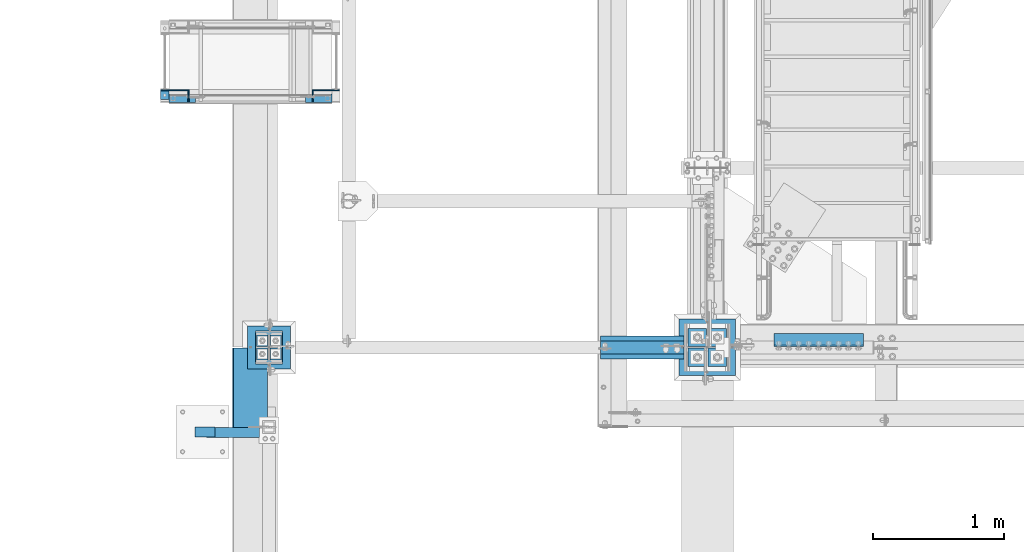
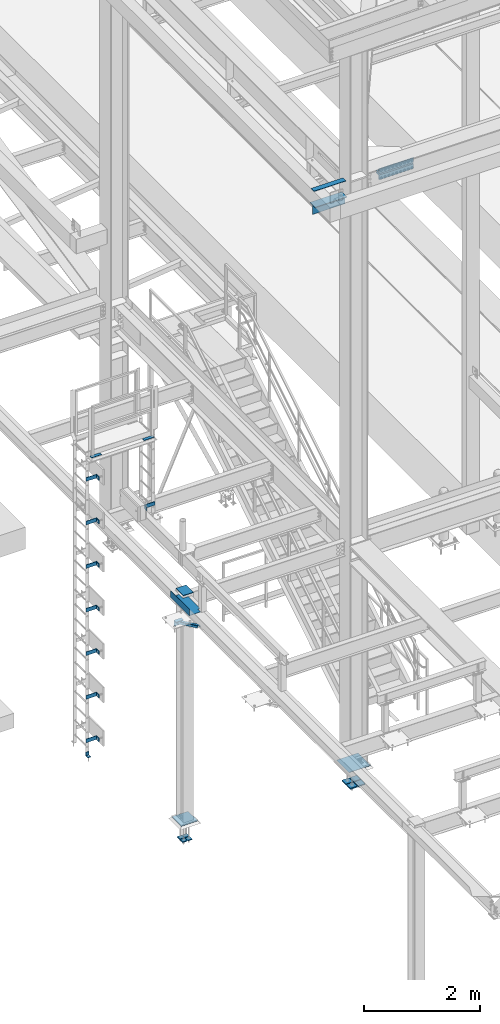
# One storey, part 2013 of 3843: 28 beams, 1 member, 12 elements without a shape of their own.
"""IFC2X3 building model written with IfcOpenShell, lengths in millimetres."""

from ifc_helpers import new_model, si_unit, frame, origin_with_axes, place, context, subcontext, project, spatial, faceted_brep, material, type_object, element, aggregate, save


model = new_model("IFC2X3")

# Units and contexts
model_context = context("Model", 3, precision=1e-05, world=origin_with_axes())
body_context = subcontext(model_context, "Body", "Model", "MODEL_VIEW")
ifc_project = project(units=[si_unit("LENGTHUNIT", "METRE", prefix="MILLI"), si_unit("AREAUNIT", "SQUARE_METRE"), si_unit("VOLUMEUNIT", "CUBIC_METRE"), si_unit("MASSUNIT", "GRAM", prefix="KILO"), si_unit("TIMEUNIT", "SECOND"), si_unit("PLANEANGLEUNIT", "RADIAN"), si_unit("SOLIDANGLEUNIT", "STERADIAN"), si_unit("THERMODYNAMICTEMPERATUREUNIT", "DEGREE_CELSIUS"), si_unit("LUMINOUSINTENSITYUNIT", "LUMEN")], contexts=[model_context])

# Site, building, storey
site_placement = place(None, origin_with_axes())
site = spatial("IfcSite", under=ifc_project, at=site_placement, CompositionType="ELEMENT")
building_placement = place(site_placement, origin_with_axes())
building = spatial("IfcBuilding", under=site, at=building_placement, Name="Undefined", CompositionType="ELEMENT")
storey_placement = place(building_placement, origin_with_axes())
storey = spatial("IfcBuildingStorey", under=building, at=storey_placement, Name="Undefined", CompositionType="ELEMENT", Elevation=0.0)

# Assembly, beams
assembly_1_placement = place(storey_placement, origin_with_axes())
assembly_1 = element("IfcElementAssembly", 1, at=assembly_1_placement, inside=storey, Name="LADDER", AssemblyPlace="NOTDEFINED", PredefinedType="RIGID_FRAME")
ifc_material_1 = material(Name="STEEL/A36")
beam_type_1 = type_object("IfcBeamType", PredefinedType="NOTDEFINED")
beam_1_placement = place(assembly_1_placement, frame((32400.1940668828, 27582.8124999999, 36281.9334228516), z_axis=(0.0, 0.0, 1.0), x_axis=(1.0, 0.0, 0.0)))
beam_1 = element("IfcBeam", 2, at=beam_1_placement, type_object=beam_type_1, material=ifc_material_1, Name="BENT_PLATE", context=body_context, shape_type="Brep", body=[
    faceted_brep([(0.0, -4.76250000000073, -38.0999999999985), (0.0, -4.76250000000073, 38.0999999999985), (0.0, 4.76250000000073, 38.0999999999985), (0.0, 4.76250000000073, -38.0999999999985), (212.923438000009, 4.76249999999345, 38.0999999999985), (212.923438000009, 4.76249999999345, -38.0999999999985), (203.398438000007, -4.762500000008, -38.0999999999985), (203.398438000007, -4.762500000008, 38.0999999999985), (212.923438000009, -87.3125000000073, 38.0999999999985), (212.923438000009, -87.3125000000073, -38.0999999999985), (203.398438000007, -87.3125000000073, 38.0999999999985), (203.398438000007, -87.3125000000073, -38.0999999999985)], [[[0, 1, 2, 3]], [[3, 2, 4, 5]], [[1, 0, 6, 7]], [[5, 4, 8, 9]], [[4, 2, 1, 7, 10, 8]], [[7, 6, 11, 10]], [[6, 0, 3, 5, 9, 11]], [[10, 11, 9, 8]]]),
])
beam_2_placement = place(assembly_1_placement, frame((32400.1940668828, 27582.8124999999, 35367.5334228516), z_axis=(0.0, 0.0, 1.0), x_axis=(1.0, 0.0, 0.0)))
beam_2 = element("IfcBeam", 3, at=beam_2_placement, type_object=beam_type_1, material=ifc_material_1, Name="BENT_PLATE", context=body_context, shape_type="Brep", body=[
    faceted_brep([(0.0, -4.76250000000073, -38.0999999999985), (0.0, -4.76250000000073, 38.0999999999985), (0.0, 4.76250000000073, 38.0999999999985), (0.0, 4.76250000000073, -38.0999999999985), (212.923438000009, 4.76249999999345, 38.0999999999985), (212.923438000009, 4.76249999999345, -38.0999999999985), (203.398438000007, -4.762500000008, -38.0999999999985), (203.398438000007, -4.762500000008, 38.0999999999985), (212.923438000009, -87.3125000000073, 38.0999999999985), (212.923438000009, -87.3125000000073, -38.0999999999985), (203.398438000007, -87.3125000000073, 38.0999999999985), (203.398438000007, -87.3125000000073, -38.0999999999985)], [[[0, 1, 2, 3]], [[3, 2, 4, 5]], [[1, 0, 6, 7]], [[5, 4, 8, 9]], [[4, 2, 1, 7, 10, 8]], [[7, 6, 11, 10]], [[6, 0, 3, 5, 9, 11]], [[10, 11, 9, 8]]]),
])
beam_3_placement = place(assembly_1_placement, frame((32400.1940668828, 27582.8124999999, 34453.1334228516), z_axis=(0.0, 0.0, 1.0), x_axis=(1.0, 0.0, 0.0)))
beam_3 = element("IfcBeam", 4, at=beam_3_placement, type_object=beam_type_1, material=ifc_material_1, Name="BENT_PLATE", context=body_context, shape_type="Brep", body=[
    faceted_brep([(0.0, -4.76250000000073, -38.0999999999985), (0.0, -4.76250000000073, 38.0999999999985), (0.0, 4.76250000000073, 38.0999999999985), (0.0, 4.76250000000073, -38.0999999999985), (212.923438000009, 4.76249999999345, 38.0999999999985), (212.923438000009, 4.76249999999345, -38.0999999999985), (203.398438000007, -4.762500000008, -38.0999999999985), (203.398438000007, -4.762500000008, 38.0999999999985), (212.923438000009, -87.3125000000073, 38.0999999999985), (212.923438000009, -87.3125000000073, -38.0999999999985), (203.398438000007, -87.3125000000073, 38.0999999999985), (203.398438000007, -87.3125000000073, -38.0999999999985)], [[[0, 1, 2, 3]], [[3, 2, 4, 5]], [[1, 0, 6, 7]], [[5, 4, 8, 9]], [[4, 2, 1, 7, 10, 8]], [[7, 6, 11, 10]], [[6, 0, 3, 5, 9, 11]], [[10, 11, 9, 8]]]),
])
beam_4_placement = place(assembly_1_placement, frame((32400.1940668828, 27582.8124999999, 33538.7334228516), z_axis=(0.0, 0.0, 1.0), x_axis=(1.0, 0.0, 0.0)))
beam_4 = element("IfcBeam", 5, at=beam_4_placement, type_object=beam_type_1, material=ifc_material_1, Name="BENT_PLATE", context=body_context, shape_type="Brep", body=[
    faceted_brep([(0.0, -4.76250000000073, -38.0999999999985), (0.0, -4.76250000000073, 38.0999999999985), (0.0, 4.76250000000073, 38.0999999999985), (0.0, 4.76250000000073, -38.0999999999985), (212.923438000009, 4.76249999999345, 38.0999999999985), (212.923438000009, 4.76249999999345, -38.0999999999985), (203.398438000007, -4.762500000008, -38.0999999999985), (203.398438000007, -4.762500000008, 38.0999999999985), (212.923438000009, -87.3125000000073, 38.0999999999985), (212.923438000009, -87.3125000000073, -38.0999999999985), (203.398438000007, -87.3125000000073, 38.0999999999985), (203.398438000007, -87.3125000000073, -38.0999999999985)], [[[0, 1, 2, 3]], [[3, 2, 4, 5]], [[1, 0, 6, 7]], [[5, 4, 8, 9]], [[4, 2, 1, 7, 10, 8]], [[7, 6, 11, 10]], [[6, 0, 3, 5, 9, 11]], [[10, 11, 9, 8]]]),
])
beam_5_placement = place(assembly_1_placement, frame((32400.1940668828, 27582.8124999999, 32624.3334228516), z_axis=(0.0, 0.0, 1.0), x_axis=(1.0, 0.0, 0.0)))
beam_5 = element("IfcBeam", 6, at=beam_5_placement, type_object=beam_type_1, material=ifc_material_1, Name="BENT_PLATE", context=body_context, shape_type="Brep", body=[
    faceted_brep([(0.0, -4.76250000000073, -38.0999999999985), (0.0, -4.76250000000073, 38.0999999999985), (0.0, 4.76250000000073, 38.0999999999985), (0.0, 4.76250000000073, -38.0999999999985), (212.923438000009, 4.76249999999345, 38.0999999999985), (212.923438000009, 4.76249999999345, -38.0999999999985), (203.398438000007, -4.762500000008, -38.0999999999985), (203.398438000007, -4.762500000008, 38.0999999999985), (212.923438000009, -87.3125000000073, 38.0999999999985), (212.923438000009, -87.3125000000073, -38.0999999999985), (203.398438000007, -87.3125000000073, 38.0999999999985), (203.398438000007, -87.3125000000073, -38.0999999999985)], [[[0, 1, 2, 3]], [[3, 2, 4, 5]], [[1, 0, 6, 7]], [[5, 4, 8, 9]], [[4, 2, 1, 7, 10, 8]], [[7, 6, 11, 10]], [[6, 0, 3, 5, 9, 11]], [[10, 11, 9, 8]]]),
])
beam_6_placement = place(assembly_1_placement, frame((32400.1940668828, 27582.8124999999, 31709.9334228516), z_axis=(0.0, 0.0, 1.0), x_axis=(1.0, 0.0, 0.0)))
beam_6 = element("IfcBeam", 7, at=beam_6_placement, type_object=beam_type_1, material=ifc_material_1, Name="BENT_PLATE", context=body_context, shape_type="Brep", body=[
    faceted_brep([(0.0, -4.76250000000073, -38.0999999999985), (0.0, -4.76250000000073, 38.0999999999985), (0.0, 4.76250000000073, 38.0999999999985), (0.0, 4.76250000000073, -38.0999999999985), (212.923438000009, 4.76249999999345, 38.0999999999985), (212.923438000009, 4.76249999999345, -38.0999999999985), (203.398438000007, -4.762500000008, -38.0999999999985), (203.398438000007, -4.762500000008, 38.0999999999985), (212.923438000009, -87.3125000000073, 38.0999999999985), (212.923438000009, -87.3125000000073, -38.0999999999985), (203.398438000007, -87.3125000000073, 38.0999999999985), (203.398438000007, -87.3125000000073, -38.0999999999985)], [[[0, 1, 2, 3]], [[3, 2, 4, 5]], [[1, 0, 6, 7]], [[5, 4, 8, 9]], [[4, 2, 1, 7, 10, 8]], [[7, 6, 11, 10]], [[6, 0, 3, 5, 9, 11]], [[10, 11, 9, 8]]]),
])

# Assembly, beam
assembly_2_placement = place(storey_placement, origin_with_axes())
assembly_2 = element("IfcElementAssembly", 8, at=assembly_2_placement, inside=storey, Name="LADDER", AssemblyPlace="NOTDEFINED", PredefinedType="RIGID_FRAME")
beam_7_placement = place(assembly_2_placement, frame((33761.4528544921, 27582.8124999999, 35306.0009490967), z_axis=(0.0, 0.0, 1.0), x_axis=(-1.0, 0.0, 0.0)))
beam_7 = element("IfcBeam", 9, at=beam_7_placement, type_object=beam_type_1, material=ifc_material_1, Name="BENT_PLATE", context=body_context, shape_type="Brep", body=[
    faceted_brep([(0.0, -4.76250000000073, -38.0999999999985), (0.0, -4.76250000000073, 38.0999999999985), (0.0, 4.76250000000073, 38.0999999999985), (0.0, 4.76250000000073, -38.0999999999985), (199.032813000005, 4.762500000008, 38.0999999999985), (199.032813000005, 4.762500000008, -38.0999999999985), (208.557812999999, -4.76249999999345, -38.0999999999985), (208.557812999999, -4.76249999999345, 38.0999999999985), (199.032813000005, 87.3125000000109, 38.0999999999985), (199.032813000005, 87.3125000000109, -38.0999999999985), (208.557812999999, 87.3125000000109, 38.0999999999985), (208.557812999999, 87.3125000000109, -38.0999999999985)], [[[0, 1, 2, 3]], [[3, 2, 4, 5]], [[1, 0, 6, 7]], [[5, 4, 8, 9]], [[4, 2, 1, 7, 10, 8]], [[7, 6, 11, 10]], [[6, 0, 3, 5, 9, 11]], [[10, 11, 9, 8]]]),
])
aggregate(assembly_2, [beam_7])

# Beam
beam_8_placement = place(assembly_1_placement, frame((32400.1940668828, 27582.8124999999, 30795.5334228516), z_axis=(0.0, 0.0, 1.0), x_axis=(1.0, 0.0, 0.0)))
beam_8 = element("IfcBeam", 10, at=beam_8_placement, type_object=beam_type_1, material=ifc_material_1, Name="BENT_PLATE", context=body_context, shape_type="Brep", body=[
    faceted_brep([(0.0, -4.76250000000073, -38.0999999999985), (0.0, -4.76250000000073, 38.0999999999985), (0.0, 4.76250000000073, 38.0999999999985), (0.0, 4.76250000000073, -38.0999999999985), (212.923438000009, 4.76249999999345, 38.0999999999985), (212.923438000009, 4.76249999999345, -38.0999999999985), (203.398438000007, -4.762500000008, -38.0999999999985), (203.398438000007, -4.762500000008, 38.0999999999985), (212.923438000009, -87.3125000000073, 38.0999999999985), (212.923438000009, -87.3125000000073, -38.0999999999985), (203.398438000007, -87.3125000000073, 38.0999999999985), (203.398438000007, -87.3125000000073, -38.0999999999985)], [[[0, 1, 2, 3]], [[3, 2, 4, 5]], [[1, 0, 6, 7]], [[5, 4, 8, 9]], [[4, 2, 1, 7, 10, 8]], [[7, 6, 11, 10]], [[6, 0, 3, 5, 9, 11]], [[10, 11, 9, 8]]]),
])

ifc_material_2 = material(Name="STEEL/A572-50")
beam_type_2 = type_object("IfcBeamType", Name="L3X3X3/8", PredefinedType="NOTDEFINED")
beam_9_placement = place(assembly_1_placement, frame((32457.5233459473, 27549.4749999999, 30518.1), z_axis=(0.0, -1.0, 0.0), x_axis=(-1.0, 0.0, 0.0)))
beam_9 = element("IfcBeam", 11, at=beam_9_placement, type_object=beam_type_2, material=ifc_material_2, Name="ANGLE", ObjectType="L3X3X3/8", context=body_context, shape_type="Brep", body=[
    faceted_brep([(0.0, 38.0999999999985, -38.0999999999985), (0.0, 38.0999999999985, 38.0999999999985), (63.5, 38.0999999999985, 38.0999999999985), (63.5, 38.0999999999985, -38.0999999999985), (0.0, 28.5750000000007, 38.0999999999985), (63.5, 28.5750000000007, 38.0999999999985), (0.0, 28.5750000000007, -28.5750000000007), (63.5, 28.5750000000007, -28.5750000000007), (0.0, -38.0999999999985, -28.5750000000007), (63.5, -38.0999999999985, -28.5750000000007), (0.0, -38.0999999999985, -38.0999999999985), (63.5, -38.0999999999985, -38.0999999999985)], [[[0, 1, 2, 3]], [[1, 4, 5, 2]], [[4, 6, 7, 5]], [[6, 8, 9, 7]], [[8, 10, 11, 9]], [[10, 0, 3, 11]], [[5, 7, 9, 11, 3, 2]], [[10, 8, 6, 4, 1, 0]]]),
])

aggregate(assembly_1, [beam_1, beam_2, beam_3, beam_4, beam_5, beam_6, beam_9, beam_8])

# Assembly, beams
assembly_3_placement = place(storey_placement, origin_with_axes())
assembly_3 = element("IfcElementAssembly", 12, at=assembly_3_placement, inside=storey, Name="RAIL", AssemblyPlace="NOTDEFINED", PredefinedType="RIGID_FRAME")
beam_type_3 = type_object("IfcBeamType", PredefinedType="NOTDEFINED")
beam_10_placement = place(assembly_3_placement, frame((33704.6093748092, 27520.8999999999, 36768.7510559082), z_axis=(0.0, -1.0, 0.0), x_axis=(-1.0, 0.0, 0.0)))
beam_10 = element("IfcBeam", 13, at=beam_10_placement, type_object=beam_type_3, material=ifc_material_1, context=body_context, shape_type="Brep", body=[
    faceted_brep([(0.0, 3.17500000000291, -31.75), (0.0, 3.17500000000291, 31.75), (203.199998088516, 3.17500000000291, 31.75), (203.199998088516, 3.17500000000291, -31.75), (0.0, -3.17500000000291, 31.75), (203.199998088516, -3.17500000000291, 31.75), (0.0, -3.17500000000291, -31.75), (203.199998088516, -3.17500000000291, -31.75)], [[[0, 1, 2, 3]], [[1, 4, 5, 2]], [[4, 6, 7, 5]], [[6, 0, 3, 7]], [[5, 7, 3, 2]], [[6, 4, 1, 0]]]),
])
beam_11_placement = place(assembly_3_placement, frame((32660.6296738373, 27520.8999999999, 36768.7510559082), z_axis=(0.0, -1.0, 0.0), x_axis=(-1.0, 0.0, 0.0)))
beam_11 = element("IfcBeam", 14, at=beam_11_placement, type_object=beam_type_3, material=ifc_material_1, context=body_context, shape_type="Brep", body=[
    faceted_brep([(0.0, 3.17500000000291, -31.75), (0.0, 3.17500000000291, 31.75), (203.199998088516, 3.17500000000291, 31.75), (203.199998088516, 3.17500000000291, -31.75), (0.0, -3.17500000000291, 31.75), (203.199998088516, -3.17500000000291, 31.75), (0.0, -3.17500000000291, -31.75), (203.199998088516, -3.17500000000291, -31.75)], [[[0, 1, 2, 3]], [[1, 4, 5, 2]], [[4, 6, 7, 5]], [[6, 0, 3, 7]], [[5, 7, 3, 2]], [[6, 4, 1, 0]]]),
])
aggregate(assembly_3, [beam_10, beam_11])

# Assembly, beam
assembly_4_placement = place(storey_placement, origin_with_axes())
assembly_4 = element("IfcElementAssembly", 15, at=assembly_4_placement, inside=storey, Name="COLUMN", AssemblyPlace="NOTDEFINED", PredefinedType="RIGID_FRAME")
ifc_material_3 = material(Name="STEEL/A992")
beam_type_4 = type_object("IfcBeamType", Name="WT8X18", PredefinedType="NOTDEFINED")
beam_12_placement = place(assembly_4_placement, frame((35760.025, 25615.9, 41962.3875), z_axis=(0.0, 0.0, 1.0), x_axis=(1.0, 0.0, 0.0)))
beam_12 = element("IfcBeam", 16, at=beam_12_placement, type_object=beam_type_4, material=ifc_material_3, Name="BEAM", ObjectType="WT8X18", context=body_context, shape_type="Brep", body=[
    faceted_brep([(-1.45519152283669e-11, 3.96875, -100.012499999997), (-1.45519152283669e-11, 3.96875, 88.9000000000015), (638.175000000003, 3.96875, 88.9000000000015), (638.175000000003, 3.96875, -100.012499999997), (-2.18278728425503e-10, 88.8999999999942, 88.9000000000015), (638.175000000003, 88.9000000000015, 88.9000000000015), (-2.18278728425503e-10, 88.8999999999942, 100.012499999997), (638.175000000003, 88.9000000000015, 100.012499999997), (2.03726813197136e-10, -88.8999999999942, 100.012499999997), (638.175000000003, -88.9000000000015, 100.012499999997), (2.03726813197136e-10, -88.8999999999942, 88.9000000000015), (638.175000000003, -88.9000000000015, 88.9000000000015), (0.0, -3.96875, 88.9000000000015), (638.175000000003, -3.96875, 88.9000000000015), (0.0, -3.96875, -100.012499999997), (638.175000000003, -3.96875, -100.012499999997)], [[[0, 1, 2, 3]], [[1, 4, 5, 2]], [[4, 6, 7, 5]], [[6, 8, 9, 7]], [[8, 10, 11, 9]], [[10, 12, 13, 11]], [[12, 14, 15, 13]], [[14, 0, 3, 15]], [[5, 7, 9, 11, 13, 15, 3, 2]], [[14, 12, 10, 8, 6, 4, 1, 0]]]),
])
aggregate(assembly_4, [beam_12])

assembly_5_placement = place(storey_placement, origin_with_axes())
assembly_5 = element("IfcElementAssembly", 17, at=assembly_5_placement, inside=storey, Name="PLATE", AssemblyPlace="NOTDEFINED", PredefinedType="RIGID_FRAME")
beam_type_5 = type_object("IfcBeamType", PredefinedType="NOTDEFINED")
beam_13_placement = place(assembly_5_placement, frame((35760.025, 25615.9, 42371.9625), z_axis=(0.0, 1.0, 0.0), x_axis=(1.0, 0.0, 0.0)))
beam_13 = element("IfcBeam", 18, at=beam_13_placement, type_object=beam_type_5, material=ifc_material_2, Name="PLATE", context=body_context, shape_type="Brep", body=[
    faceted_brep([(0.0, 4.76249999999709, -50.7999999999993), (0.0, 4.76249999999709, 50.7999999999993), (638.175000000003, 4.76249999999709, 50.7999999999993), (638.175000000003, 4.76249999999709, -50.7999999999993), (0.0, -4.76249999999709, 50.7999999999993), (638.175000000003, -4.76249999999709, 50.7999999999993), (0.0, -4.76249999999709, -50.7999999999993), (638.175000000003, -4.76249999999709, -50.7999999999993)], [[[0, 1, 2, 3]], [[1, 4, 5, 2]], [[4, 6, 7, 5]], [[6, 0, 3, 7]], [[5, 7, 3, 2]], [[6, 4, 1, 0]]]),
])
aggregate(assembly_5, [beam_13])

# Assembly, beams
assembly_6_placement = place(storey_placement, origin_with_axes())
assembly_6 = element("IfcElementAssembly", 19, at=assembly_6_placement, inside=storey, Name="PLATE", AssemblyPlace="NOTDEFINED", PredefinedType="RIGID_FRAME")
beam_type_6 = type_object("IfcBeamType", Name="L4X4X1/2", PredefinedType="NOTDEFINED")
beam_14_placement = place(assembly_6_placement, frame((37084.0000000004, 25673.049999999, 42297.35), z_axis=(0.0, 1.0, 0.0), x_axis=(1.0, 0.0, 0.0)))
beam_14 = element("IfcBeam", 20, at=beam_14_placement, type_object=beam_type_6, material=ifc_material_2, Name="ANGLE", ObjectType="L4X4X1/2", context=body_context, shape_type="Brep", body=[
    faceted_brep([(0.0, 50.8000000000029, -50.8000000000029), (0.0, 50.8000000000029, 50.8000000000029), (685.800000000003, 50.8000000000029, 50.8000000000029), (685.800000000003, 50.8000000000029, -50.8000000000029), (0.0, 38.0999999999985, 50.8000000000029), (685.800000000003, 38.0999999999985, 50.8000000000029), (0.0, 38.0999999999985, -38.0999999999985), (685.800000000003, 38.0999999999985, -38.1000000000058), (0.0, -50.8000000000029, -38.1000000000058), (685.800000000003, -50.8000000000029, -38.1000000000058), (0.0, -50.8000000000029, -50.8000000000029), (685.800000000003, -50.8000000000029, -50.8000000000029)], [[[0, 1, 2, 3]], [[1, 4, 5, 2]], [[4, 6, 7, 5]], [[6, 8, 9, 7]], [[8, 10, 11, 9]], [[10, 0, 3, 11]], [[5, 7, 9, 11, 3, 2]], [[10, 8, 6, 4, 1, 0]]]),
])
beam_15_placement = place(assembly_6_placement, frame((37769.8000000004, 25673.049999994, 42167.175), z_axis=(0.0, 1.0, 0.0), x_axis=(-1.0, 0.0, 0.0)))
beam_15 = element("IfcBeam", 21, at=beam_15_placement, type_object=beam_type_6, material=ifc_material_2, Name="ANGLE", ObjectType="L4X4X1/2", context=body_context, shape_type="Brep", body=[
    faceted_brep([(0.0, 50.8000000000029, -50.8000000000029), (0.0, 50.8000000000029, 50.8000000000029), (685.800000000003, 50.8000000000029, 50.8000000000029), (685.800000000003, 50.8000000000029, -50.8000000000029), (0.0, 38.0999999999985, 50.8000000000029), (685.800000000003, 38.0999999999985, 50.8000000000029), (0.0, 38.0999999999985, -38.0999999999985), (685.800000000003, 38.0999999999985, -38.1000000000058), (0.0, -50.8000000000029, -38.1000000000058), (685.800000000003, -50.8000000000029, -38.1000000000058), (0.0, -50.8000000000029, -50.8000000000029), (685.800000000003, -50.8000000000029, -50.8000000000029)], [[[0, 1, 2, 3]], [[1, 4, 5, 2]], [[4, 6, 7, 5]], [[6, 8, 9, 7]], [[8, 10, 11, 9]], [[10, 0, 3, 11]], [[5, 7, 9, 11, 3, 2]], [[10, 8, 6, 4, 1, 0]]]),
])
aggregate(assembly_6, [beam_14, beam_15])

# Assembly, beam
assembly_7_placement = place(storey_placement, origin_with_axes())
assembly_7 = element("IfcElementAssembly", 22, at=assembly_7_placement, inside=storey, Name="ANGLE", AssemblyPlace="NOTDEFINED", PredefinedType="RIGID_FRAME")
beam_type_7 = type_object("IfcBeamType", Name="L5X3X1/4", PredefinedType="NOTDEFINED")
beam_16_placement = place(assembly_7_placement, frame((32808.7812541416, 24969.7875, 34737.675), z_axis=(0.0, 0.0, -1.0), x_axis=(-1.0, 0.0, 0.0)))
beam_16 = element("IfcBeam", 23, at=beam_16_placement, type_object=beam_type_7, material=ifc_material_2, Name="ANGLE", ObjectType="L5X3X1/4", context=body_context, shape_type="Brep", body=[
    faceted_brep([(0.0, 38.0999999999985, -63.5), (0.0, 38.0999999999985, 63.5), (152.400000000001, 38.0999999999985, 63.5), (152.399999999994, 38.0999999999985, -63.5), (0.0, 31.75, 63.5), (152.400000000001, 31.75, 63.5), (0.0, 31.75, -57.1500000000015), (152.400000000001, 31.75, -57.1500000000015), (0.0, -38.0999999999985, -57.1500000000015), (152.400000000001, -38.0999999999985, -57.1500000000015), (0.0, -38.0999999999985, -63.5), (152.400000000001, -38.0999999999985, -63.5)], [[[0, 1, 2, 3]], [[1, 4, 5, 2]], [[4, 6, 7, 5]], [[6, 8, 9, 7]], [[8, 10, 11, 9]], [[10, 0, 3, 11]], [[5, 7, 9, 11, 3, 2]], [[10, 8, 6, 4, 1, 0]]]),
])
aggregate(assembly_7, [beam_16])

# Assembly, member
assembly_8_placement = place(storey_placement, origin_with_axes())
assembly_8 = element("IfcElementAssembly", 24, at=assembly_8_placement, inside=storey, Name="ANGLE", AssemblyPlace="NOTDEFINED", PredefinedType="RIGID_FRAME")
member_type = type_object("IfcMemberType", Name="L3X3X1/4", PredefinedType="NOTDEFINED")
member_placement = place(assembly_8_placement, frame((32728.2664806695, 24963.4375, 34747.2), z_axis=(0.0, -1.0, 0.0), x_axis=(0.866025404271339, 0.0, -0.499999999156664)))
member = element("IfcMember", 25, at=member_placement, type_object=member_type, material=ifc_material_2, Name="ANGLE", ObjectType="L3X3X1/4", context=body_context, shape_type="Brep", body=[
    faceted_brep([(0.0, 38.0999999999985, -38.0999999999985), (0.0, 38.0999999999985, 38.0999999999985), (467.63681744217, 38.0999999998385, 38.0999999999985), (467.63681744217, 38.0999999998385, -38.0999999999985), (0.0, 31.75, 38.0999999999985), (467.636817442166, 31.7499999998472, 38.0999999999985), (0.0, 31.75, -31.75), (467.636817442166, 31.7499999998472, -31.75), (0.0, -38.0999999999985, -31.75), (467.636817442151, -38.1000000000349, -31.75), (0.0, -38.0999999999985, -38.0999999999985), (467.636817442151, -38.1000000000349, -38.0999999999985)], [[[0, 1, 2, 3]], [[1, 4, 5, 2]], [[4, 6, 7, 5]], [[6, 8, 9, 7]], [[8, 10, 11, 9]], [[10, 0, 3, 11]], [[5, 7, 9, 11, 3, 2]], [[10, 8, 6, 4, 1, 0]]]),
])
aggregate(assembly_8, [member])

# Assembly, beam
assembly_9_placement = place(storey_placement, origin_with_axes())
assembly_9 = element("IfcElementAssembly", 26, at=assembly_9_placement, inside=storey, Name="COLUMN", AssemblyPlace="NOTDEFINED", PredefinedType="RIGID_FRAME")
beam_type_8 = type_object("IfcBeamType", PredefinedType="NOTDEFINED")
beam_17_placement = place(assembly_9_placement, frame((33223.2, 25490.4875, 34855.15), z_axis=(1.0, 0.0, 0.0), x_axis=(0.0, 1.0, 0.0)))
beam_17 = element("IfcBeam", 27, at=beam_17_placement, type_object=beam_type_8, material=ifc_material_2, Name="PLATE", context=body_context, shape_type="Brep", body=[
    faceted_brep([(1.74622982740402e-10, 6.35000000000582, -101.600000000195), (-1.67347025126219e-10, 6.35000000000582, 101.600000000151), (250.825000000001, 6.34999999999854, 101.600000000006), (250.825000000001, 6.34999999999854, -101.600000000006), (-1.67347025126219e-10, -6.35000000000582, 101.600000000151), (250.825000000001, -6.34999999999854, 101.600000000006), (1.74622982740402e-10, -6.35000000000582, -101.600000000195), (250.825000000001, -6.34999999999854, -101.600000000006)], [[[0, 1, 2, 3]], [[1, 4, 5, 2]], [[4, 6, 7, 5]], [[6, 0, 3, 7]], [[5, 7, 3, 2]], [[6, 4, 1, 0]]]),
])
aggregate(assembly_9, [beam_17])

# Assembly, beams
assembly_10_placement = place(storey_placement, origin_with_axes())
assembly_10 = element("IfcElementAssembly", 28, at=assembly_10_placement, inside=storey, Name="TEMPLATE", AssemblyPlace="NOTDEFINED", PredefinedType="RIGID_FRAME")
beam_type_9 = type_object("IfcBeamType", PredefinedType="NOTDEFINED")
beam_18_placement = place(assembly_10_placement, frame((33172.4, 25520.65, 29659.2625), z_axis=(1.0, 0.0, 0.0), x_axis=(0.0, 1.0, 0.0)))
beam_18 = element("IfcBeam", 29, at=beam_18_placement, type_object=beam_type_9, material=ifc_material_2, context=body_context, shape_type="Brep", body=[
    faceted_brep([(0.0, 7.9375, -44.4499999999971), (0.0, 7.9375, 44.4499999999971), (88.8999999999942, 7.9375, 44.4499999999971), (88.8999999999942, 7.9375, -44.4499999999971), (0.0, -7.9375, 44.4499999999971), (88.8999999999942, -7.9375, 44.4499999999971), (0.0, -7.9375, -44.4499999999971), (88.8999999999942, -7.9375, -44.4499999999971)], [[[0, 1, 2, 3]], [[1, 4, 5, 2]], [[4, 6, 7, 5]], [[6, 0, 3, 7]], [[5, 7, 3, 2]], [[6, 4, 1, 0]]]),
])
beam_19_placement = place(assembly_10_placement, frame((33274.0, 25520.65, 29659.2625), z_axis=(1.0, 0.0, 0.0), x_axis=(0.0, 1.0, 0.0)))
beam_19 = element("IfcBeam", 30, at=beam_19_placement, type_object=beam_type_9, material=ifc_material_2, context=body_context, shape_type="Brep", body=[
    faceted_brep([(0.0, 7.9375, -44.4499999999971), (0.0, 7.9375, 44.4499999999971), (88.8999999999942, 7.9375, 44.4499999999971), (88.8999999999942, 7.9375, -44.4499999999971), (0.0, -7.9375, 44.4499999999971), (88.8999999999942, -7.9375, 44.4499999999971), (0.0, -7.9375, -44.4499999999971), (88.8999999999942, -7.9375, -44.4499999999971)], [[[0, 1, 2, 3]], [[1, 4, 5, 2]], [[4, 6, 7, 5]], [[6, 0, 3, 7]], [[5, 7, 3, 2]], [[6, 4, 1, 0]]]),
])
beam_20_placement = place(assembly_10_placement, frame((33172.4, 25622.25, 29659.2625), z_axis=(1.0, 0.0, 0.0), x_axis=(0.0, 1.0, 0.0)))
beam_20 = element("IfcBeam", 31, at=beam_20_placement, type_object=beam_type_9, material=ifc_material_2, context=body_context, shape_type="Brep", body=[
    faceted_brep([(0.0, 7.9375, -44.4499999999971), (0.0, 7.9375, 44.4499999999971), (88.8999999999942, 7.9375, 44.4499999999971), (88.8999999999942, 7.9375, -44.4499999999971), (0.0, -7.9375, 44.4499999999971), (88.8999999999942, -7.9375, 44.4499999999971), (0.0, -7.9375, -44.4499999999971), (88.8999999999942, -7.9375, -44.4499999999971)], [[[0, 1, 2, 3]], [[1, 4, 5, 2]], [[4, 6, 7, 5]], [[6, 0, 3, 7]], [[5, 7, 3, 2]], [[6, 4, 1, 0]]]),
])
beam_21_placement = place(assembly_10_placement, frame((33274.0, 25622.25, 29659.2625), z_axis=(1.0, 0.0, 0.0), x_axis=(0.0, 1.0, 0.0)))
beam_21 = element("IfcBeam", 32, at=beam_21_placement, type_object=beam_type_9, material=ifc_material_2, context=body_context, shape_type="Brep", body=[
    faceted_brep([(0.0, 7.9375, -44.4499999999971), (0.0, 7.9375, 44.4499999999971), (88.8999999999942, 7.9375, 44.4499999999971), (88.8999999999942, 7.9375, -44.4499999999971), (0.0, -7.9375, 44.4499999999971), (88.8999999999942, -7.9375, 44.4499999999971), (0.0, -7.9375, -44.4499999999971), (88.8999999999942, -7.9375, -44.4499999999971)], [[[0, 1, 2, 3]], [[1, 4, 5, 2]], [[4, 6, 7, 5]], [[6, 0, 3, 7]], [[5, 7, 3, 2]], [[6, 4, 1, 0]]]),
])

# Assembly, beam
assembly_11_placement = place(storey_placement, origin_with_axes())
assembly_11 = element("IfcElementAssembly", 33, at=assembly_11_placement, inside=storey, Name="BEAM", AssemblyPlace="NOTDEFINED", PredefinedType="RIGID_FRAME")
beam_type_10 = type_object("IfcBeamType", PredefinedType="NOTDEFINED")
beam_22_placement = place(assembly_11_placement, frame((33210.5, 25292.05, 34813.875), z_axis=(0.0, -1.0, 0.0), x_axis=(-1.0, 0.0, 0.0)))
beam_22 = element("IfcBeam", 34, at=beam_22_placement, type_object=beam_type_10, material=ifc_material_1, Name="BENT_PLATE", context=body_context, shape_type="Brep", body=[
    faceted_brep([(44.4500000000044, -3.17500000000291, 228.599999999999), (44.4500000000044, 3.17500000000291, 228.599999999999), (0.0, 3.17500000000291, 228.599999999999), (0.0, -3.17500000000291, 228.599999999999), (44.4500000000044, 0.0, 320.675500000001), (44.4500000000044, 3.17500000000291, 320.675500000001), (44.4500000000044, -3.17500000000291, 317.500500000013), (0.0, -3.17500000000291, -185.737500000007), (0.0, 3.17500000000291, -185.737500000007), (101.60000000002, 3.17500000000291, -185.737500000014), (101.60000000002, -3.17500000000291, -185.737500000014), (101.599999999991, 3.17500000000291, -320.675500000001), (101.599999999991, -3.17500000000291, -320.675500000001), (266.700012207031, 3.17500000000291, -320.675500000001), (266.700012207031, -136.524996948239, -320.675500000001), (260.350012207025, -136.524996948239, -320.675500000001), (260.350012207025, -3.17500000000291, -320.675500000001), (266.700012207031, 3.17500000000291, 320.675500000001), (266.700012207031, -136.524996948239, 320.675500000001), (263.525012207036, -136.524996948239, 320.675500000016), (260.350012207025, -136.524996948239, 317.500500000013), (260.350012207025, -3.17500000000291, 317.500500000013), (263.525012207036, 7.27595761418343e-12, 320.675500000016)], [[[0, 1, 2, 3]], [[4, 5, 1, 0, 6]], [[7, 8, 9, 10]], [[10, 9, 11, 12]], [[13, 14, 15, 16, 12, 11]], [[13, 17, 18, 14]], [[15, 14, 18, 19, 20]], [[16, 15, 20, 21]], [[19, 22, 21, 20]], [[21, 22, 4, 6]], [[3, 7, 10, 12, 16, 21, 6, 0]], [[8, 7, 3, 2]], [[17, 13, 11, 9, 8, 2, 1, 5]], [[22, 19, 18, 17, 5, 4]]]),
])
aggregate(assembly_11, [beam_22])

# Beam
beam_type_11 = type_object("IfcBeamType", PredefinedType="NOTDEFINED")
beam_23_placement = place(assembly_10_placement, frame((33223.2, 25450.8004997253, 30063.2815), z_axis=(-1.0, 0.0, 0.0), x_axis=(0.0, 1.0, 0.0)))
beam_23 = element("IfcBeam", 35, at=beam_23_placement, type_object=beam_type_11, material=ifc_material_2, Name="TEMPLATE", context=body_context, shape_type="Brep", body=[
    faceted_brep([(0.0, 2.38149999999951, -165.100000000006), (0.0, 2.38149999999951, 165.100000000006), (330.199996948242, 2.38149999999951, 165.100000000006), (330.199996948242, 2.38149999999951, -165.100000000006), (0.0, -2.38149999999951, 165.100000000006), (330.199996948242, -2.38149999999951, 165.100000000006), (0.0, -2.38149999999951, -165.100000000006), (330.199996948242, -2.38149999999951, -165.100000000006)], [[[0, 1, 2, 3]], [[1, 4, 5, 2]], [[4, 6, 7, 5]], [[6, 0, 3, 7]], [[5, 7, 3, 2]], [[6, 4, 1, 0]]]),
])

aggregate(assembly_10, [beam_18, beam_19, beam_20, beam_21, beam_23])

# Assembly, beams
assembly_12_placement = place(storey_placement, origin_with_axes())
assembly_12 = element("IfcElementAssembly", 36, at=assembly_12_placement, inside=storey, Name="TEMPLATE", AssemblyPlace="NOTDEFINED", PredefinedType="RIGID_FRAME")
beam_type_12 = type_object("IfcBeamType", PredefinedType="NOTDEFINED")
beam_24_placement = place(assembly_12_placement, frame((36722.05, 25539.7, 29656.0875), z_axis=(0.0, 1.0, 0.0), x_axis=(-1.0, 0.0, 0.0)))
beam_24 = element("IfcBeam", 37, at=beam_24_placement, type_object=beam_type_12, material=ifc_material_2, context=body_context, shape_type="Brep", body=[
    faceted_brep([(0.0, 11.1124999999993, -69.8499999999985), (0.0, 11.1124999999993, 69.8499999999985), (139.699999999997, 11.1124999999993, 69.8499999999985), (139.699999999997, 11.1124999999993, -69.8499999999985), (0.0, -11.1124999999993, 69.8499999999985), (139.699999999997, -11.1124999999993, 69.8499999999985), (0.0, -11.1124999999993, -69.8499999999985), (139.699999999997, -11.1124999999993, -69.8499999999985)], [[[0, 1, 2, 3]], [[1, 4, 5, 2]], [[4, 6, 7, 5]], [[6, 0, 3, 7]], [[5, 7, 3, 2]], [[6, 4, 1, 0]]]),
])
beam_25_placement = place(assembly_12_placement, frame((36722.05, 25692.1, 29656.0875), z_axis=(0.0, 1.0, 0.0), x_axis=(-1.0, 0.0, 0.0)))
beam_25 = element("IfcBeam", 38, at=beam_25_placement, type_object=beam_type_12, material=ifc_material_2, context=body_context, shape_type="Brep", body=[
    faceted_brep([(0.0, 11.1124999999993, -69.8499999999985), (0.0, 11.1124999999993, 69.8499999999985), (139.699999999997, 11.1124999999993, 69.8499999999985), (139.699999999997, 11.1124999999993, -69.8499999999985), (0.0, -11.1124999999993, 69.8499999999985), (139.699999999997, -11.1124999999993, 69.8499999999985), (0.0, -11.1124999999993, -69.8499999999985), (139.699999999997, -11.1124999999993, -69.8499999999985)], [[[0, 1, 2, 3]], [[1, 4, 5, 2]], [[4, 6, 7, 5]], [[6, 0, 3, 7]], [[5, 7, 3, 2]], [[6, 4, 1, 0]]]),
])
beam_26_placement = place(assembly_12_placement, frame((36569.65, 25539.7, 29656.0875), z_axis=(0.0, 1.0, 0.0), x_axis=(-1.0, 0.0, 0.0)))
beam_26 = element("IfcBeam", 39, at=beam_26_placement, type_object=beam_type_12, material=ifc_material_2, context=body_context, shape_type="Brep", body=[
    faceted_brep([(0.0, 11.1124999999993, -69.8499999999985), (0.0, 11.1124999999993, 69.8499999999985), (139.699999999997, 11.1124999999993, 69.8499999999985), (139.699999999997, 11.1124999999993, -69.8499999999985), (0.0, -11.1124999999993, 69.8499999999985), (139.699999999997, -11.1124999999993, 69.8499999999985), (0.0, -11.1124999999993, -69.8499999999985), (139.699999999997, -11.1124999999993, -69.8499999999985)], [[[0, 1, 2, 3]], [[1, 4, 5, 2]], [[4, 6, 7, 5]], [[6, 0, 3, 7]], [[5, 7, 3, 2]], [[6, 4, 1, 0]]]),
])
beam_27_placement = place(assembly_12_placement, frame((36569.65, 25692.1, 29656.0875), z_axis=(0.0, 1.0, 0.0), x_axis=(-1.0, 0.0, 0.0)))
beam_27 = element("IfcBeam", 40, at=beam_27_placement, type_object=beam_type_12, material=ifc_material_2, context=body_context, shape_type="Brep", body=[
    faceted_brep([(0.0, 11.1124999999993, -69.8499999999985), (0.0, 11.1124999999993, 69.8499999999985), (139.699999999997, 11.1124999999993, 69.8499999999985), (139.699999999997, 11.1124999999993, -69.8499999999985), (0.0, -11.1124999999993, 69.8499999999985), (139.699999999997, -11.1124999999993, 69.8499999999985), (0.0, -11.1124999999993, -69.8499999999985), (139.699999999997, -11.1124999999993, -69.8499999999985)], [[[0, 1, 2, 3]], [[1, 4, 5, 2]], [[4, 6, 7, 5]], [[6, 0, 3, 7]], [[5, 7, 3, 2]], [[6, 4, 1, 0]]]),
])
beam_type_13 = type_object("IfcBeamType", PredefinedType="NOTDEFINED")
beam_28_placement = place(assembly_12_placement, frame((36791.8999984741, 25615.9, 30064.075), z_axis=(0.0, -1.0, 0.0), x_axis=(-1.0, 0.0, 0.0)))
beam_28 = element("IfcBeam", 41, at=beam_28_placement, type_object=beam_type_13, material=ifc_material_2, Name="TEMPLATE", context=body_context, shape_type="Brep", body=[
    faceted_brep([(0.0, 3.17499999999927, -215.900000000001), (0.0, 3.17499999999927, 215.900000000001), (431.799999999988, 3.17499999999927, 215.900000000001), (431.799999999988, 3.17499999999927, -215.900000000001), (0.0, -3.17499999999927, 215.900000000001), (431.799999999988, -3.17499999999927, 215.900000000001), (0.0, -3.17499999999927, -215.900000000001), (431.799999999988, -3.17499999999927, -215.900000000001)], [[[0, 1, 2, 3]], [[1, 4, 5, 2]], [[4, 6, 7, 5]], [[6, 0, 3, 7]], [[5, 7, 3, 2]], [[6, 4, 1, 0]]]),
])
aggregate(assembly_12, [beam_24, beam_25, beam_26, beam_27, beam_28])

save(model, "model.ifc")
